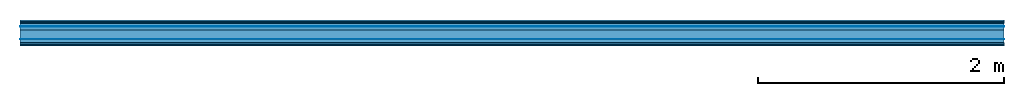
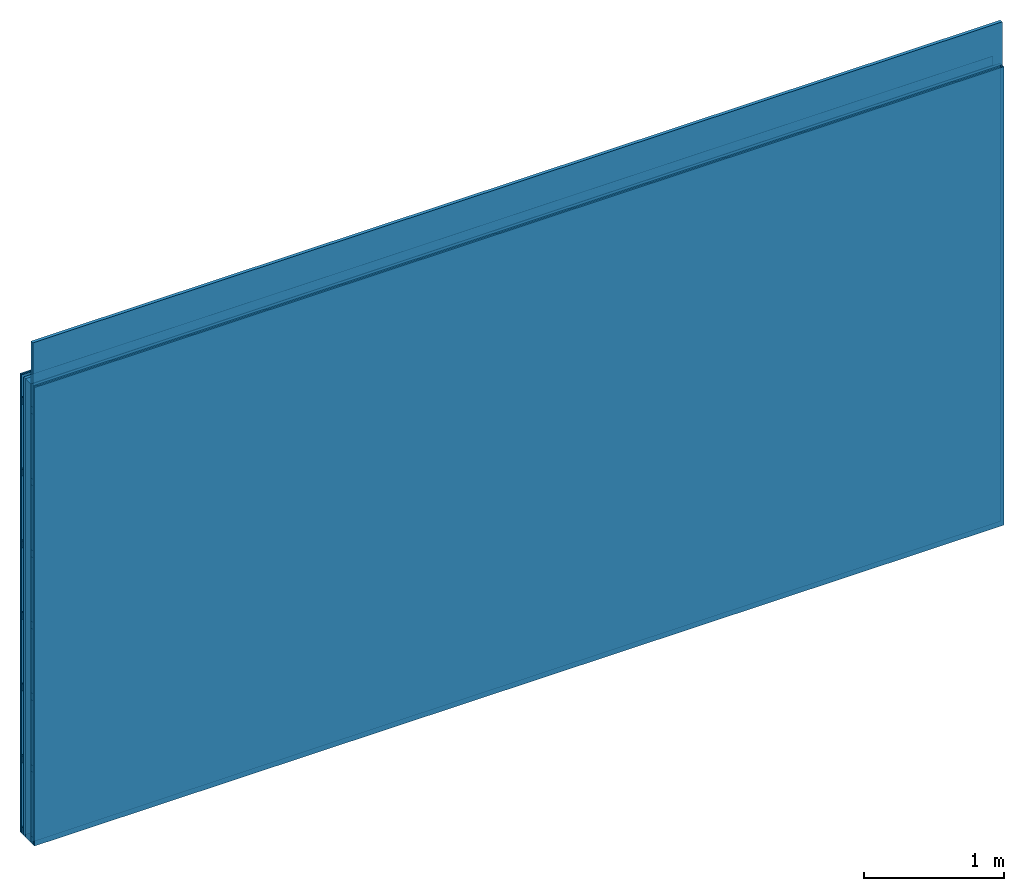
# One storey: 7 plates, 4 members, 1 element without a shape of its own.
"""IFC4 building model written with IfcOpenShell, lengths in metres."""

from ifc_helpers import new_model, si_unit, derived_unit, direction, frame, frame_2d, origin, origin_with_axes, place, context, project, spatial, rectangle, extrude, material, layer, layer_set, type_object, element, aggregate, save


model = new_model("IFC4")

# Units and contexts
plan_context = context("Plan", 3, precision=1e-05, world=origin(), true_north=direction((0.0, 1.0)))
model_context = context("Model", 3, precision=1e-05, world=origin(), true_north=direction((0.0, 1.0)))
ifc_project = project(units=[si_unit("LENGTHUNIT", "METRE"), derived_unit("SOUNDPRESSUREUNIT", [(si_unit("PRESSUREUNIT", "PASCAL", prefix="MICRO"), 0)]), si_unit("ENERGYUNIT", "JOULE", prefix="MEGA"), si_unit("MASSUNIT", "GRAM", prefix="KILO"), derived_unit("THERMALTRANSMITTANCEUNIT", [(si_unit("POWERUNIT", "WATT"), 1), (si_unit("AREAUNIT", "SQUARE_METRE"), -1), (si_unit("THERMODYNAMICTEMPERATUREUNIT", "KELVIN"), -1)]), derived_unit("AREADENSITYUNIT", [(si_unit("MASSUNIT", "GRAM", prefix="KILO"), 1), (si_unit("AREAUNIT", "SQUARE_METRE"), -1)]), derived_unit("USERDEFINED", [(si_unit("ENERGYUNIT", "JOULE", prefix="MEGA"), 1), (si_unit("AREAUNIT", "SQUARE_METRE"), -1)])], contexts=[plan_context, model_context])

# Site, building, storey
site = spatial("IfcSite", under=ifc_project)
building_placement = place(None, origin())
building = spatial("IfcBuilding", under=site, at=building_placement)
storey_placement = place(building_placement, origin())
storey = spatial("IfcBuildingStorey", under=building, at=storey_placement)

# Wall, members, plates
ifc_material_1 = material(Name="joints", Category="04.017")
ifc_layer_1 = layer(ifc_material_1, 0.0, Name="Surface")
ifc_material_2 = material(Name="Rigidur H", Category="03.007")
ifc_layer_2 = layer(ifc_material_2, 0.0125, Name="Cover 2nd layer")
ifc_layer_3 = layer(ifc_material_2, 0.0125, Name="Cover 1st layer")
ifc_layer_4 = layer(None, 0.027, Name="Battens / profiles")
ifc_material_3 = material(Name="Air")
ifc_layer_5 = layer(ifc_material_3, 0.001, Name="Coupling")
ifc_material_4 = material(Category="10.008")
ifc_layer_6 = layer(ifc_material_4, 0.027, Name="Cavity")
ifc_material_5 = material(Name="no composite action")
ifc_layer_7 = layer(ifc_material_5, 0.0, Name="Bond")
ifc_layer_8 = layer(None, 0.075, Name="Support")
ifc_layer_9 = layer(ifc_material_5, 0.0, Name="Bond")
ifc_layer_10 = layer(ifc_material_3, 0.001, Name="Coupling")
ifc_layer_11 = layer(None, 0.027, Name="Battens / profiles")
ifc_layer_12 = layer(ifc_material_2, 0.0125, Name="Covering 1st layer")
ifc_layer_13 = layer(ifc_material_2, 0.0125, Name="Covering 2nd layer")
ifc_layer_14 = layer(ifc_material_1, 0.0, Name="Surface")
ifc_layer_set = layer_set([ifc_layer_1, ifc_layer_2, ifc_layer_3, ifc_layer_4, ifc_layer_5, ifc_layer_6, ifc_layer_7, ifc_layer_8, ifc_layer_9, ifc_layer_10, ifc_layer_11, ifc_layer_12, ifc_layer_13, ifc_layer_14])
wall_type = type_object("IfcWallType", Name="C0475", PredefinedType="NOTDEFINED", material=ifc_layer_set)
wall_placement = place(None, frame((0.0, 0.0, 0.0), z_axis=(0.0, -1.0, 0.0), x_axis=(1.0, 0.0, 0.0)))
wall = element("IfcWall", 1, at=wall_placement, inside=storey, type_object=wall_type, material=ifc_layer_set, Name="Wall #1")
ifc_material_6 = material()
member_1_placement = place(wall_placement, origin())
member_1 = element("IfcMember", 2, at=member_1_placement, material=ifc_material_6, Name="Battens / profiles", context=plan_context, shape_type="SweptSolid", body=[
    extrude(rectangle(XDim=0.06, YDim=0.027, at=frame_2d((0.03, 0.0135), x_axis=(1.0, 0.0))), frame((0.0, 0.0, 0.025), z_axis=(1.0, 0.0, 0.0), x_axis=(0.0, 1.0, 0.0)), (0.0, 0.0, 1.0), 8.0),
    extrude(rectangle(XDim=0.06, YDim=0.027, at=frame_2d((0.03, 0.0135), x_axis=(1.0, 0.0))), frame((0.0, 0.625, 0.025), z_axis=(1.0, 0.0, 0.0), x_axis=(0.0, 1.0, 0.0)), (0.0, 0.0, 1.0), 8.0),
    extrude(rectangle(XDim=0.06, YDim=0.027, at=frame_2d((0.03, 0.0135), x_axis=(1.0, 0.0))), frame((0.0, 1.25, 0.025), z_axis=(1.0, 0.0, 0.0), x_axis=(0.0, 1.0, 0.0)), (0.0, 0.0, 1.0), 8.0),
    extrude(rectangle(XDim=0.06, YDim=0.027, at=frame_2d((0.03, 0.0135), x_axis=(1.0, 0.0))), frame((0.0, 1.875, 0.025), z_axis=(1.0, 0.0, 0.0), x_axis=(0.0, 1.0, 0.0)), (0.0, 0.0, 1.0), 8.0),
    extrude(rectangle(XDim=0.06, YDim=0.027, at=frame_2d((0.03, 0.0135), x_axis=(1.0, 0.0))), frame((0.0, 2.5, 0.025), z_axis=(1.0, 0.0, 0.0), x_axis=(0.0, 1.0, 0.0)), (0.0, 0.0, 1.0), 8.0),
    extrude(rectangle(XDim=0.06, YDim=0.027, at=frame_2d((0.03, 0.0135), x_axis=(1.0, 0.0))), frame((0.0, 3.125, 0.025), z_axis=(1.0, 0.0, 0.0), x_axis=(0.0, 1.0, 0.0)), (0.0, 0.0, 1.0), 8.0),
    extrude(rectangle(XDim=0.06, YDim=0.027, at=frame_2d((0.03, 0.0135), x_axis=(1.0, 0.0))), frame((0.0, 3.75, 0.025), z_axis=(1.0, 0.0, 0.0), x_axis=(0.0, 1.0, 0.0)), (0.0, 0.0, 1.0), 8.0),
])
ifc_material_7 = material(Name="OSB")
member_2_placement = place(wall_placement, origin())
member_2 = element("IfcMember", 3, at=member_2_placement, material=ifc_material_7, Name="Support", context=plan_context, shape_type="SweptSolid", body=[
    extrude(rectangle(XDim=1.0, YDim=0.075, at=frame_2d((0.5, 0.0375), x_axis=(1.0, 0.0))), frame((0.0, 4.0, 0.08), z_axis=(0.0, -1.0, 0.0), x_axis=(1.0, 0.0, 0.0)), (0.0, 0.0, 1.0), 4.0),
    extrude(rectangle(XDim=1.0, YDim=0.075, at=frame_2d((0.5, 0.0375), x_axis=(1.0, 0.0))), frame((1.0, 4.0, 0.08), z_axis=(0.0, -1.0, 0.0), x_axis=(1.0, 0.0, 0.0)), (0.0, 0.0, 1.0), 4.0),
    extrude(rectangle(XDim=1.0, YDim=0.075, at=frame_2d((0.5, 0.0375), x_axis=(1.0, 0.0))), frame((2.0, 4.0, 0.08), z_axis=(0.0, -1.0, 0.0), x_axis=(1.0, 0.0, 0.0)), (0.0, 0.0, 1.0), 4.0),
    extrude(rectangle(XDim=1.0, YDim=0.075, at=frame_2d((0.5, 0.0375), x_axis=(1.0, 0.0))), frame((3.0, 4.0, 0.08), z_axis=(0.0, -1.0, 0.0), x_axis=(1.0, 0.0, 0.0)), (0.0, 0.0, 1.0), 4.0),
    extrude(rectangle(XDim=1.0, YDim=0.075, at=frame_2d((0.5, 0.0375), x_axis=(1.0, 0.0))), frame((4.0, 4.0, 0.08), z_axis=(0.0, -1.0, 0.0), x_axis=(1.0, 0.0, 0.0)), (0.0, 0.0, 1.0), 4.0),
    extrude(rectangle(XDim=1.0, YDim=0.075, at=frame_2d((0.5, 0.0375), x_axis=(1.0, 0.0))), frame((5.0, 4.0, 0.08), z_axis=(0.0, -1.0, 0.0), x_axis=(1.0, 0.0, 0.0)), (0.0, 0.0, 1.0), 4.0),
    extrude(rectangle(XDim=1.0, YDim=0.075, at=frame_2d((0.5, 0.0375), x_axis=(1.0, 0.0))), frame((6.0, 4.0, 0.08), z_axis=(0.0, -1.0, 0.0), x_axis=(1.0, 0.0, 0.0)), (0.0, 0.0, 1.0), 4.0),
    extrude(rectangle(XDim=1.0, YDim=0.075, at=frame_2d((0.5, 0.0375), x_axis=(1.0, 0.0))), frame((7.0, 4.0, 0.08), z_axis=(0.0, -1.0, 0.0), x_axis=(1.0, 0.0, 0.0)), (0.0, 0.0, 1.0), 4.0),
])
member_3_placement = place(wall_placement, origin())
member_3 = element("IfcMember", 4, at=member_3_placement, material=ifc_material_6, Name="Battens / profiles", context=plan_context, shape_type="SweptSolid", body=[
    extrude(rectangle(XDim=0.06, YDim=0.027, at=frame_2d((0.03, 0.0135), x_axis=(1.0, 0.0))), frame((0.0, 0.0, 0.156), z_axis=(1.0, 0.0, 0.0), x_axis=(0.0, 1.0, 0.0)), (0.0, 0.0, 1.0), 8.0),
    extrude(rectangle(XDim=0.06, YDim=0.027, at=frame_2d((0.03, 0.0135), x_axis=(1.0, 0.0))), frame((0.0, 0.625, 0.156), z_axis=(1.0, 0.0, 0.0), x_axis=(0.0, 1.0, 0.0)), (0.0, 0.0, 1.0), 8.0),
    extrude(rectangle(XDim=0.06, YDim=0.027, at=frame_2d((0.03, 0.0135), x_axis=(1.0, 0.0))), frame((0.0, 1.25, 0.156), z_axis=(1.0, 0.0, 0.0), x_axis=(0.0, 1.0, 0.0)), (0.0, 0.0, 1.0), 8.0),
    extrude(rectangle(XDim=0.06, YDim=0.027, at=frame_2d((0.03, 0.0135), x_axis=(1.0, 0.0))), frame((0.0, 1.875, 0.156), z_axis=(1.0, 0.0, 0.0), x_axis=(0.0, 1.0, 0.0)), (0.0, 0.0, 1.0), 8.0),
    extrude(rectangle(XDim=0.06, YDim=0.027, at=frame_2d((0.03, 0.0135), x_axis=(1.0, 0.0))), frame((0.0, 2.5, 0.156), z_axis=(1.0, 0.0, 0.0), x_axis=(0.0, 1.0, 0.0)), (0.0, 0.0, 1.0), 8.0),
    extrude(rectangle(XDim=0.06, YDim=0.027, at=frame_2d((0.03, 0.0135), x_axis=(1.0, 0.0))), frame((0.0, 3.125, 0.156), z_axis=(1.0, 0.0, 0.0), x_axis=(0.0, 1.0, 0.0)), (0.0, 0.0, 1.0), 8.0),
    extrude(rectangle(XDim=0.06, YDim=0.027, at=frame_2d((0.03, 0.0135), x_axis=(1.0, 0.0))), frame((0.0, 3.75, 0.156), z_axis=(1.0, 0.0, 0.0), x_axis=(0.0, 1.0, 0.0)), (0.0, 0.0, 1.0), 8.0),
])
member_4_placement = place(wall_placement, origin())
member_4 = element("IfcMember", 5, at=member_4_placement, material=ifc_material_4, Name="Cavity", context=plan_context, shape_type="SweptSolid", body=[
    extrude(rectangle(XDim=0.565, YDim=0.027, at=frame_2d((0.2825, 0.0135), x_axis=(1.0, 0.0))), frame((0.0, 0.06, 0.156), z_axis=(1.0, 0.0, 0.0), x_axis=(0.0, 1.0, 0.0)), (0.0, 0.0, 1.0), 8.0),
    extrude(rectangle(XDim=0.565, YDim=0.027, at=frame_2d((0.2825, 0.0135), x_axis=(1.0, 0.0))), frame((0.0, 0.685, 0.156), z_axis=(1.0, 0.0, 0.0), x_axis=(0.0, 1.0, 0.0)), (0.0, 0.0, 1.0), 8.0),
    extrude(rectangle(XDim=0.565, YDim=0.027, at=frame_2d((0.2825, 0.0135), x_axis=(1.0, 0.0))), frame((0.0, 1.31, 0.156), z_axis=(1.0, 0.0, 0.0), x_axis=(0.0, 1.0, 0.0)), (0.0, 0.0, 1.0), 8.0),
    extrude(rectangle(XDim=0.565, YDim=0.027, at=frame_2d((0.2825, 0.0135), x_axis=(1.0, 0.0))), frame((0.0, 1.935, 0.156), z_axis=(1.0, 0.0, 0.0), x_axis=(0.0, 1.0, 0.0)), (0.0, 0.0, 1.0), 8.0),
    extrude(rectangle(XDim=0.565, YDim=0.027, at=frame_2d((0.2825, 0.0135), x_axis=(1.0, 0.0))), frame((0.0, 2.56, 0.156), z_axis=(1.0, 0.0, 0.0), x_axis=(0.0, 1.0, 0.0)), (0.0, 0.0, 1.0), 8.0),
    extrude(rectangle(XDim=0.565, YDim=0.027, at=frame_2d((0.2825, 0.0135), x_axis=(1.0, 0.0))), frame((0.0, 3.185, 0.156), z_axis=(1.0, 0.0, 0.0), x_axis=(0.0, 1.0, 0.0)), (0.0, 0.0, 1.0), 8.0),
    extrude(rectangle(XDim=0.565, YDim=0.027, at=frame_2d((0.2825, 0.0135), x_axis=(1.0, 0.0))), frame((0.0, 3.81, 0.156), z_axis=(1.0, 0.0, 0.0), x_axis=(0.0, 1.0, 0.0)), (0.0, 0.0, 1.0), 8.0),
])
plate_1_placement = place(wall_placement, origin())
plate_1 = element("IfcPlate", 6, at=plate_1_placement, material=ifc_material_2, Name="Cover 2nd layer", context=plan_context, shape_type="SweptSolid", body=[
    extrude(rectangle(XDim=8.0, YDim=4.0, at=frame_2d((4.0, 2.0), x_axis=(1.0, 0.0))), origin_with_axes(), (0.0, 0.0, 1.0), 0.0125),
])
plate_2_placement = place(wall_placement, origin())
plate_2 = element("IfcPlate", 7, at=plate_2_placement, material=ifc_material_2, Name="Cover 1st layer", context=plan_context, shape_type="SweptSolid", body=[
    extrude(rectangle(XDim=8.0, YDim=4.0, at=frame_2d((4.0, 2.0), x_axis=(1.0, 0.0))), frame((0.0, 0.0, 0.0125), z_axis=(0.0, 0.0, 1.0), x_axis=(1.0, 0.0, 0.0)), (0.0, 0.0, 1.0), 0.0125),
])
plate_3_placement = place(wall_placement, origin())
plate_3 = element("IfcPlate", 8, at=plate_3_placement, material=ifc_material_3, Name="Coupling", context=plan_context, shape_type="SweptSolid", body=[
    extrude(rectangle(XDim=8.0, YDim=4.0, at=frame_2d((4.0, 2.0), x_axis=(1.0, 0.0))), frame((0.0, 0.0, 0.052), z_axis=(0.0, 0.0, 1.0), x_axis=(1.0, 0.0, 0.0)), (0.0, 0.0, 1.0), 0.001),
])
plate_4_placement = place(wall_placement, origin())
plate_4 = element("IfcPlate", 9, at=plate_4_placement, material=ifc_material_4, Name="Cavity", context=plan_context, shape_type="SweptSolid", body=[
    extrude(rectangle(XDim=8.0, YDim=4.0, at=frame_2d((4.0, 2.0), x_axis=(1.0, 0.0))), frame((0.0, 0.0, 0.053), z_axis=(0.0, 0.0, 1.0), x_axis=(1.0, 0.0, 0.0)), (0.0, 0.0, 1.0), 0.027),
])
plate_5_placement = place(wall_placement, origin())
plate_5 = element("IfcPlate", 10, at=plate_5_placement, material=ifc_material_3, Name="Coupling", context=plan_context, shape_type="SweptSolid", body=[
    extrude(rectangle(XDim=8.0, YDim=4.0, at=frame_2d((4.0, 2.0), x_axis=(1.0, 0.0))), frame((0.0, 0.0, 0.155), z_axis=(0.0, 0.0, 1.0), x_axis=(1.0, 0.0, 0.0)), (0.0, 0.0, 1.0), 0.001),
])
plate_6_placement = place(wall_placement, origin())
plate_6 = element("IfcPlate", 11, at=plate_6_placement, material=ifc_material_2, Name="Covering 1st layer", context=plan_context, shape_type="SweptSolid", body=[
    extrude(rectangle(XDim=8.0, YDim=4.0, at=frame_2d((4.0, 2.0), x_axis=(1.0, 0.0))), frame((0.0, 0.0, 0.183), z_axis=(0.0, 0.0, 1.0), x_axis=(1.0, 0.0, 0.0)), (0.0, 0.0, 1.0), 0.0125),
])
plate_7_placement = place(wall_placement, origin())
plate_7 = element("IfcPlate", 12, at=plate_7_placement, material=ifc_material_2, Name="Covering 2nd layer", context=plan_context, shape_type="SweptSolid", body=[
    extrude(rectangle(XDim=8.0, YDim=4.0, at=frame_2d((4.0, 2.0), x_axis=(1.0, 0.0))), frame((0.0, 0.0, 0.1955), z_axis=(0.0, 0.0, 1.0), x_axis=(1.0, 0.0, 0.0)), (0.0, 0.0, 1.0), 0.0125),
])
aggregate(wall, [plate_1, plate_2, member_1, plate_3, plate_4, member_2, plate_5, member_3, member_4, plate_6, plate_7])

save(model, "model.ifc")
